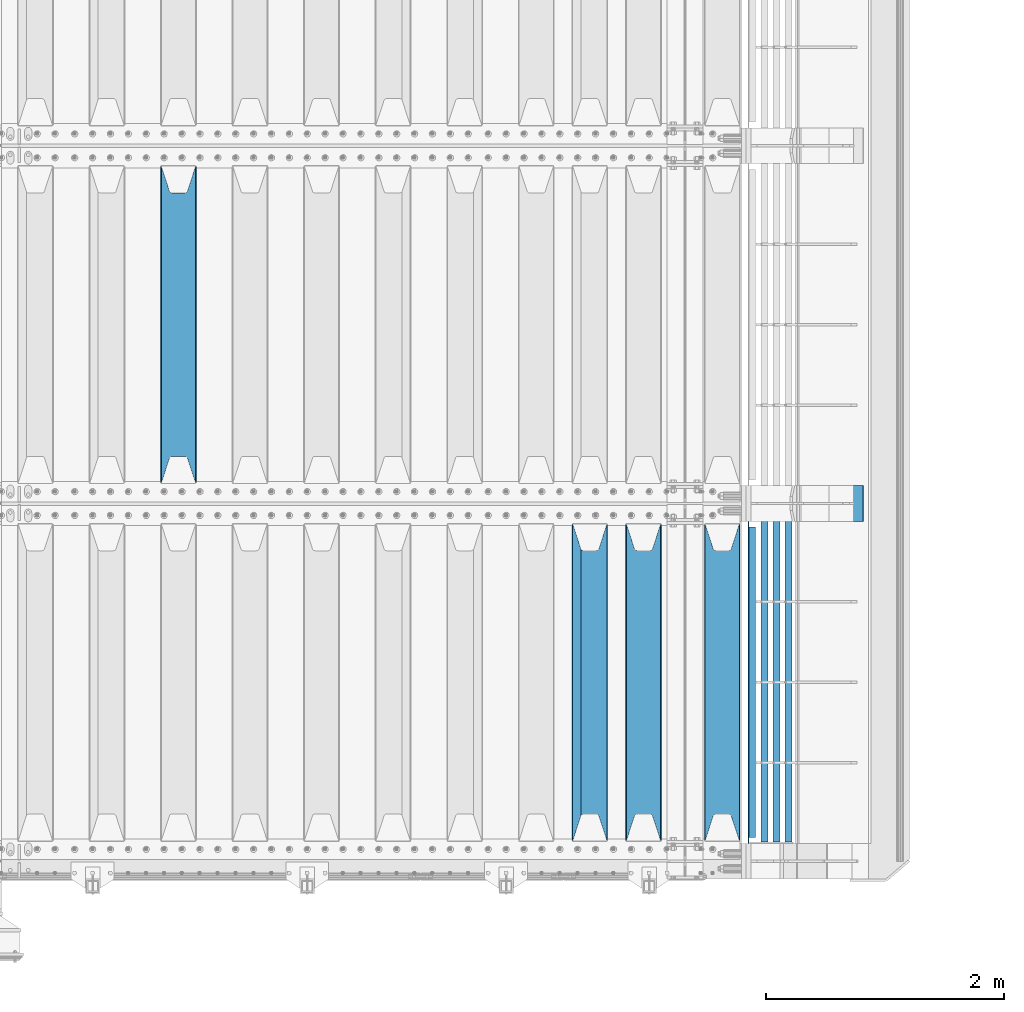
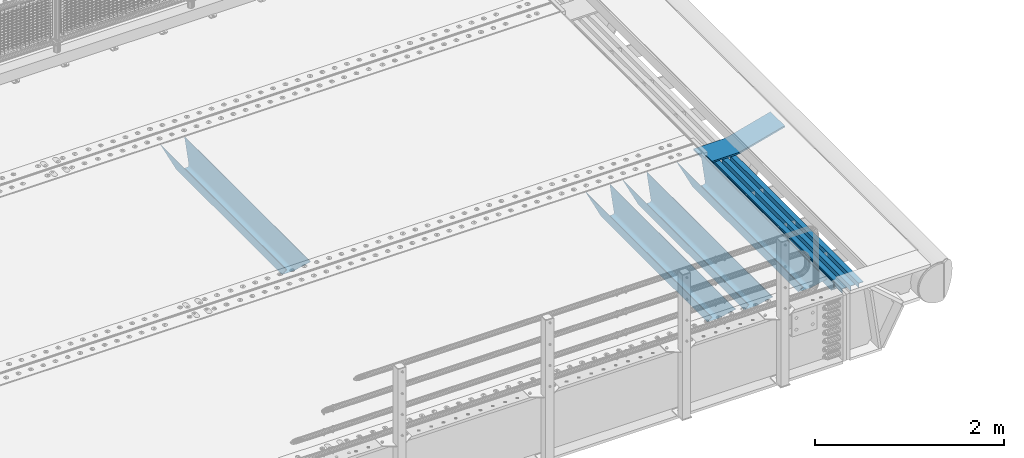
# One storey, part 141 of 270: 9 beams.
"""IFC2X3 building model written with IfcOpenShell, lengths in millimetres."""

from ifc_helpers import new_model, si_unit, frame, origin_with_axes, place, context, subcontext, project, spatial, faceted_brep, material, type_object, element, save


model = new_model("IFC2X3")

# Units and contexts
model_context = context("Model", 3, precision=1e-05, world=origin_with_axes())
body_context = subcontext(model_context, "Body", "Model", "MODEL_VIEW")
ifc_project = project(units=[si_unit("LENGTHUNIT", "METRE", prefix="MILLI"), si_unit("AREAUNIT", "SQUARE_METRE"), si_unit("VOLUMEUNIT", "CUBIC_METRE"), si_unit("MASSUNIT", "GRAM", prefix="KILO"), si_unit("TIMEUNIT", "SECOND"), si_unit("PLANEANGLEUNIT", "RADIAN"), si_unit("SOLIDANGLEUNIT", "STERADIAN"), si_unit("THERMODYNAMICTEMPERATUREUNIT", "DEGREE_CELSIUS"), si_unit("LUMINOUSINTENSITYUNIT", "LUMEN")], contexts=[model_context])

# Site, building, storey
site_placement = place(None, origin_with_axes())
site = spatial("IfcSite", under=ifc_project, at=site_placement, CompositionType="ELEMENT")
building_placement = place(site_placement, origin_with_axes())
building = spatial("IfcBuilding", under=site, at=building_placement, Name="Standard", CompositionType="ELEMENT")
storey_placement = place(building_placement, origin_with_axes())
storey = spatial("IfcBuildingStorey", under=building, at=storey_placement, Name="Undefined", CompositionType="ELEMENT", Elevation=0.0)

# Beams
ifc_material_1 = material(Name="STEEL/S355N")
beam_type_1 = type_object("IfcBeamType", PredefinedType="NOTDEFINED")
beam_1_placement = place(storey_placement, frame((15670.0, -20825.0, -115.0), z_axis=(0.0, 0.0, 1.0), x_axis=(0.0, 1.0, 0.0)))
element("IfcBeam", 1, at=beam_1_placement, inside=storey, type_object=beam_type_1, material=ifc_material_1, context=body_context, shape_type="Brep", body=[
    faceted_brep([(0.0, 150.0, 115.0), (0.0, 143.689999999999, 115.0), (2650.00000000297, 143.689999999999, 115.0), (2650.00000000297, 150.0, 115.0), (2650.00000000297, 142.059565218398, 110.000000003096), (2650.00000000297, 148.3695652184, 110.000000003096), (2441.90079219209, -80.1103600731112, -98.0992078077845), (2437.7588105432, -77.5672621345584, -102.241189456673), (2434.06523489747, -74.4080125315522, -105.934765102404), (2430.9108609509, -70.710272125576, -109.089139048974), (2428.37322971128, -66.5649389910068, -111.626770288588), (2426.51472138055, -62.0739139532889, -113.485278619323), (2425.38102192092, -57.3475956567672, -114.618978078955), (2424.99999999987, -52.5021667386536, -115.0), (2424.99999999987, 52.5021667386536, -115.0), (2425.38102192092, 57.3475956567672, -114.618978078955), (2426.51472138055, 62.0739139532889, -113.485278619323), (2428.37322971128, 66.5649389910068, -111.626770288588), (2430.9108609509, 70.710272125576, -109.089139048974), (2434.06523489747, 74.4080125315522, -105.934765102404), (2437.7588105432, 77.5672621345584, -102.241189456673), (2441.90079219209, 80.1103600731112, -98.0992078077846), (2446.38936140511, 81.9747917625791, -93.6106385947584), (2448.2494850041, 76.2713538057251, -91.7505149957729), (2444.62967112263, 74.76777986261, -95.3703288772456), (2441.28936334126, 72.7168944282894, -98.710636658607), (2438.31067330439, 70.1691124903846, -101.689326695487), (2435.76682334747, 67.1870637758839, -104.233176652398), (2433.72034654133, 63.8440531834895, -106.279653458539), (2432.22154950042, 60.222258798236, -107.778450499454), (2431.30727574265, 56.4107117849089, -108.692724257221), (2430.99999999987, 52.5031078186876, -109.0), (2430.99999999987, -52.5031078186876, -109.0), (2431.30727574265, -56.4107117849089, -108.692724257221), (2432.22154950042, -60.222258798236, -107.778450499454), (2433.72034654133, -63.8440531834895, -106.279653458539), (2435.76682334747, -67.1870637758839, -104.233176652398), (2438.31067330438, -70.1691124903846, -101.689326695487), (2441.28936334126, -72.7168944282894, -98.7106366586071), (2444.62967112263, -74.76777986261, -95.3703288772457), (2448.2494850041, -76.2713538057251, -91.7505149957729), (2650.00000000297, -142.059565218398, 110.000000003096), (2650.00000000297, -148.3695652184, 110.000000003096), (2446.38936140511, -81.9747917625791, -93.6106385947584), (2650.00000000297, -143.689999999999, 115.0), (2650.00000000297, -150.0, 115.0), (0.0, -143.689999999999, 115.0), (0.0, -150.0, 115.0), (0.0, -148.369565218261, 110.000000002672), (203.610638597431, -81.9747917625791, -93.6106385947584), (208.099207810457, -80.1103600731112, -98.0992078077845), (212.241189459342, -77.5672621345584, -102.241189456673), (215.934765105078, -74.4080125315522, -105.934765102404), (219.089139051644, -70.710272125576, -109.089139048974), (221.626770291259, -66.5649389910068, -111.626770288588), (223.485278621993, -62.0739139532889, -113.485278619323), (224.618978081628, -57.3475956567672, -114.618978078955), (225.00000000267, -52.5021667386536, -115.0), (225.00000000267, 52.5021667386536, -115.0), (224.618978081628, 57.3475956567672, -114.618978078955), (223.485278621993, 62.0739139532889, -113.485278619323), (221.626770291259, 66.5649389910068, -111.626770288588), (219.089139051644, 70.710272125576, -109.089139048974), (215.934765105078, 74.4080125315522, -105.934765102404), (212.241189459342, 77.5672621345584, -102.241189456673), (208.099207810457, 80.1103600731112, -98.0992078077846), (203.610638597431, 81.9747917625791, -93.6106385947584), (0.0, 148.369565218261, 110.000000002672), (0.0, 142.05956521826, 110.000000002672), (201.750514998446, 76.2713538057251, -91.7505149957729), (205.370328879915, 74.76777986261, -95.3703288772456), (208.710636661279, 72.7168944282894, -98.710636658607), (211.689326698157, 70.1691124903846, -101.689326695487), (214.233176655071, 67.1870637758839, -104.233176652398), (216.27965346121, 63.8440531834895, -106.279653458539), (217.778450502126, 60.222258798236, -107.778450499454), (218.692724259894, 56.4107117849089, -108.692724257221), (219.00000000267, 52.5031078186876, -109.0), (219.00000000267, -52.5031078186876, -109.0), (218.692724259894, -56.4107117849089, -108.692724257221), (217.778450502123, -60.222258798236, -107.778450499454), (216.27965346121, -63.8440531834895, -106.279653458539), (214.233176655071, -67.1870637758839, -104.233176652398), (211.689326698157, -70.1691124903846, -101.689326695487), (208.710636661279, -72.7168944282894, -98.7106366586071), (205.370328879915, -74.76777986261, -95.3703288772457), (201.750514998446, -76.2713538057251, -91.7505149957729), (0.0, -142.05956521826, 110.000000002672)], [[[0, 1, 2, 3]], [[3, 2, 4, 5]], [[6, 7, 8, 9, 10, 11, 12, 13, 14, 15, 16, 17, 18, 19, 20, 21, 22, 5, 4, 23, 24, 25, 26, 27, 28, 29, 30, 31, 32, 33, 34, 35, 36, 37, 38, 39, 40, 41, 42, 43]], [[44, 45, 42, 41]], [[46, 47, 45, 44]], [[43, 42, 45, 47, 48, 49]], [[6, 43, 49, 50]], [[7, 6, 50, 51]], [[8, 7, 51, 52]], [[9, 8, 52, 53]], [[10, 9, 53, 54]], [[11, 10, 54, 55]], [[12, 11, 55, 56]], [[13, 12, 56, 57]], [[14, 13, 57, 58]], [[15, 14, 58, 59]], [[16, 15, 59, 60]], [[17, 16, 60, 61]], [[18, 17, 61, 62]], [[19, 18, 62, 63]], [[20, 19, 63, 64]], [[21, 20, 64, 65]], [[22, 21, 65, 66]], [[0, 3, 5, 22, 66, 67]], [[1, 0, 67, 68]], [[23, 4, 2, 1, 68, 69]], [[24, 23, 69, 70]], [[25, 24, 70, 71]], [[26, 25, 71, 72]], [[27, 26, 72, 73]], [[28, 27, 73, 74]], [[29, 28, 74, 75]], [[30, 29, 75, 76]], [[31, 30, 76, 77]], [[32, 31, 77, 78]], [[33, 32, 78, 79]], [[34, 33, 79, 80]], [[35, 34, 80, 81]], [[36, 35, 81, 82]], [[37, 36, 82, 83]], [[38, 37, 83, 84]], [[39, 38, 84, 85]], [[40, 39, 85, 86]], [[46, 44, 41, 40, 86, 87]], [[47, 46, 87, 48]], [[86, 85, 84, 83, 82, 81, 80, 79, 78, 77, 76, 75, 74, 73, 72, 71, 70, 69, 68, 67, 66, 65, 64, 63, 62, 61, 60, 59, 58, 57, 56, 55, 54, 53, 52, 51, 50, 49, 48, 87]]]),
])
beam_2_placement = place(storey_placement, frame((20230.0, -23825.0, -115.0), z_axis=(0.0, 0.0, 1.0), x_axis=(0.0, 1.0, 0.0)))
element("IfcBeam", 2, at=beam_2_placement, inside=storey, type_object=beam_type_1, material=ifc_material_1, context=body_context, shape_type="Brep", body=[
    faceted_brep([(0.0, 150.0, 115.0), (0.0, 143.689999999999, 115.0), (2650.00000000297, 143.689999999999, 115.0), (2650.00000000297, 150.0, 115.0), (2650.00000000297, 142.059565218398, 110.000000003096), (2650.00000000297, 148.3695652184, 110.000000003096), (2441.90079219209, -80.1103600731112, -98.0992078077845), (2437.7588105432, -77.5672621345584, -102.241189456673), (2434.06523489747, -74.4080125315522, -105.934765102404), (2430.9108609509, -70.710272125576, -109.089139048974), (2428.37322971128, -66.5649389910068, -111.626770288588), (2426.51472138055, -62.0739139532889, -113.485278619323), (2425.38102192092, -57.3475956567672, -114.618978078955), (2424.99999999987, -52.5021667386536, -115.0), (2424.99999999987, 52.5021667386536, -115.0), (2425.38102192092, 57.3475956567672, -114.618978078955), (2426.51472138055, 62.0739139532889, -113.485278619323), (2428.37322971128, 66.5649389910068, -111.626770288588), (2430.9108609509, 70.710272125576, -109.089139048974), (2434.06523489747, 74.4080125315522, -105.934765102404), (2437.7588105432, 77.5672621345584, -102.241189456673), (2441.90079219209, 80.1103600731112, -98.0992078077846), (2446.38936140511, 81.9747917625791, -93.6106385947584), (2448.2494850041, 76.2713538057251, -91.7505149957729), (2444.62967112263, 74.76777986261, -95.3703288772456), (2441.28936334126, 72.7168944282894, -98.710636658607), (2438.31067330439, 70.1691124903846, -101.689326695487), (2435.76682334747, 67.1870637758839, -104.233176652398), (2433.72034654133, 63.8440531834895, -106.279653458539), (2432.22154950042, 60.222258798236, -107.778450499454), (2431.30727574265, 56.4107117849089, -108.692724257221), (2430.99999999987, 52.5031078186876, -109.0), (2430.99999999987, -52.5031078186876, -109.0), (2431.30727574265, -56.4107117849089, -108.692724257221), (2432.22154950042, -60.222258798236, -107.778450499454), (2433.72034654133, -63.8440531834895, -106.279653458539), (2435.76682334747, -67.1870637758839, -104.233176652398), (2438.31067330438, -70.1691124903846, -101.689326695487), (2441.28936334126, -72.7168944282894, -98.7106366586071), (2444.62967112263, -74.76777986261, -95.3703288772457), (2448.2494850041, -76.2713538057251, -91.7505149957729), (2650.00000000297, -142.059565218398, 110.000000003096), (2650.00000000297, -148.3695652184, 110.000000003096), (2446.38936140511, -81.9747917625791, -93.6106385947584), (2650.00000000297, -143.689999999999, 115.0), (2650.00000000297, -150.0, 115.0), (0.0, -143.689999999999, 115.0), (0.0, -150.0, 115.0), (0.0, -148.369565218261, 110.000000002672), (203.610638597431, -81.9747917625791, -93.6106385947584), (208.099207810457, -80.1103600731112, -98.0992078077845), (212.241189459342, -77.5672621345584, -102.241189456673), (215.934765105078, -74.4080125315522, -105.934765102404), (219.089139051644, -70.710272125576, -109.089139048974), (221.626770291259, -66.5649389910068, -111.626770288588), (223.485278621993, -62.0739139532889, -113.485278619323), (224.618978081628, -57.3475956567672, -114.618978078955), (225.00000000267, -52.5021667386536, -115.0), (225.00000000267, 52.5021667386536, -115.0), (224.618978081628, 57.3475956567672, -114.618978078955), (223.485278621993, 62.0739139532889, -113.485278619323), (221.626770291259, 66.5649389910068, -111.626770288588), (219.089139051644, 70.710272125576, -109.089139048974), (215.934765105078, 74.4080125315522, -105.934765102404), (212.241189459342, 77.5672621345584, -102.241189456673), (208.099207810457, 80.1103600731112, -98.0992078077846), (203.610638597431, 81.9747917625791, -93.6106385947584), (0.0, 148.369565218261, 110.000000002672), (0.0, 142.05956521826, 110.000000002672), (201.750514998446, 76.2713538057251, -91.7505149957729), (205.370328879915, 74.76777986261, -95.3703288772456), (208.710636661279, 72.7168944282894, -98.710636658607), (211.689326698157, 70.1691124903846, -101.689326695487), (214.233176655071, 67.1870637758839, -104.233176652398), (216.27965346121, 63.8440531834895, -106.279653458539), (217.778450502126, 60.222258798236, -107.778450499454), (218.692724259894, 56.4107117849089, -108.692724257221), (219.00000000267, 52.5031078186876, -109.0), (219.00000000267, -52.5031078186876, -109.0), (218.692724259894, -56.4107117849089, -108.692724257221), (217.778450502123, -60.222258798236, -107.778450499454), (216.27965346121, -63.8440531834895, -106.279653458539), (214.233176655071, -67.1870637758839, -104.233176652398), (211.689326698157, -70.1691124903846, -101.689326695487), (208.710636661279, -72.7168944282894, -98.7106366586071), (205.370328879915, -74.76777986261, -95.3703288772457), (201.750514998446, -76.2713538057251, -91.7505149957729), (0.0, -142.05956521826, 110.000000002672)], [[[0, 1, 2, 3]], [[3, 2, 4, 5]], [[6, 7, 8, 9, 10, 11, 12, 13, 14, 15, 16, 17, 18, 19, 20, 21, 22, 5, 4, 23, 24, 25, 26, 27, 28, 29, 30, 31, 32, 33, 34, 35, 36, 37, 38, 39, 40, 41, 42, 43]], [[44, 45, 42, 41]], [[46, 47, 45, 44]], [[43, 42, 45, 47, 48, 49]], [[6, 43, 49, 50]], [[7, 6, 50, 51]], [[8, 7, 51, 52]], [[9, 8, 52, 53]], [[10, 9, 53, 54]], [[11, 10, 54, 55]], [[12, 11, 55, 56]], [[13, 12, 56, 57]], [[14, 13, 57, 58]], [[15, 14, 58, 59]], [[16, 15, 59, 60]], [[17, 16, 60, 61]], [[18, 17, 61, 62]], [[19, 18, 62, 63]], [[20, 19, 63, 64]], [[21, 20, 64, 65]], [[22, 21, 65, 66]], [[0, 3, 5, 22, 66, 67]], [[1, 0, 67, 68]], [[23, 4, 2, 1, 68, 69]], [[24, 23, 69, 70]], [[25, 24, 70, 71]], [[26, 25, 71, 72]], [[27, 26, 72, 73]], [[28, 27, 73, 74]], [[29, 28, 74, 75]], [[30, 29, 75, 76]], [[31, 30, 76, 77]], [[32, 31, 77, 78]], [[33, 32, 78, 79]], [[34, 33, 79, 80]], [[35, 34, 80, 81]], [[36, 35, 81, 82]], [[37, 36, 82, 83]], [[38, 37, 83, 84]], [[39, 38, 84, 85]], [[40, 39, 85, 86]], [[46, 44, 41, 40, 86, 87]], [[47, 46, 87, 48]], [[86, 85, 84, 83, 82, 81, 80, 79, 78, 77, 76, 75, 74, 73, 72, 71, 70, 69, 68, 67, 66, 65, 64, 63, 62, 61, 60, 59, 58, 57, 56, 55, 54, 53, 52, 51, 50, 49, 48, 87]]]),
])
beam_3_placement = place(storey_placement, frame((19570.0, -23825.0, -115.0), z_axis=(0.0, 0.0, 1.0), x_axis=(0.0, 1.0, 0.0)))
element("IfcBeam", 3, at=beam_3_placement, inside=storey, type_object=beam_type_1, material=ifc_material_1, context=body_context, shape_type="Brep", body=[
    faceted_brep([(0.0, 150.0, 115.0), (0.0, 143.689999999999, 115.0), (2650.00000000297, 143.689999999999, 115.0), (2650.00000000297, 150.0, 115.0), (2650.00000000297, 142.059565218398, 110.000000003096), (2650.00000000297, 148.3695652184, 110.000000003096), (2441.90079219209, -80.1103600731112, -98.0992078077845), (2437.7588105432, -77.5672621345584, -102.241189456673), (2434.06523489747, -74.4080125315522, -105.934765102404), (2430.9108609509, -70.710272125576, -109.089139048974), (2428.37322971128, -66.5649389910068, -111.626770288588), (2426.51472138055, -62.0739139532889, -113.485278619323), (2425.38102192092, -57.3475956567672, -114.618978078955), (2424.99999999987, -52.5021667386536, -115.0), (2424.99999999987, 52.5021667386536, -115.0), (2425.38102192092, 57.3475956567672, -114.618978078955), (2426.51472138055, 62.0739139532889, -113.485278619323), (2428.37322971128, 66.5649389910068, -111.626770288588), (2430.9108609509, 70.710272125576, -109.089139048974), (2434.06523489747, 74.4080125315522, -105.934765102404), (2437.7588105432, 77.5672621345584, -102.241189456673), (2441.90079219209, 80.1103600731112, -98.0992078077846), (2446.38936140511, 81.9747917625791, -93.6106385947584), (2448.2494850041, 76.2713538057251, -91.7505149957729), (2444.62967112263, 74.76777986261, -95.3703288772456), (2441.28936334126, 72.7168944282894, -98.710636658607), (2438.31067330439, 70.1691124903846, -101.689326695487), (2435.76682334747, 67.1870637758839, -104.233176652398), (2433.72034654133, 63.8440531834895, -106.279653458539), (2432.22154950042, 60.222258798236, -107.778450499454), (2431.30727574265, 56.4107117849089, -108.692724257221), (2430.99999999987, 52.5031078186876, -109.0), (2430.99999999987, -52.5031078186876, -109.0), (2431.30727574265, -56.4107117849089, -108.692724257221), (2432.22154950042, -60.222258798236, -107.778450499454), (2433.72034654133, -63.8440531834895, -106.279653458539), (2435.76682334747, -67.1870637758839, -104.233176652398), (2438.31067330438, -70.1691124903846, -101.689326695487), (2441.28936334126, -72.7168944282894, -98.7106366586071), (2444.62967112263, -74.76777986261, -95.3703288772457), (2448.2494850041, -76.2713538057251, -91.7505149957729), (2650.00000000297, -142.059565218398, 110.000000003096), (2650.00000000297, -148.3695652184, 110.000000003096), (2446.38936140511, -81.9747917625791, -93.6106385947584), (2650.00000000297, -143.689999999999, 115.0), (2650.00000000297, -150.0, 115.0), (0.0, -143.689999999999, 115.0), (0.0, -150.0, 115.0), (0.0, -148.369565218261, 110.000000002672), (203.610638597431, -81.9747917625791, -93.6106385947584), (208.099207810457, -80.1103600731112, -98.0992078077845), (212.241189459342, -77.5672621345584, -102.241189456673), (215.934765105078, -74.4080125315522, -105.934765102404), (219.089139051644, -70.710272125576, -109.089139048974), (221.626770291259, -66.5649389910068, -111.626770288588), (223.485278621993, -62.0739139532889, -113.485278619323), (224.618978081628, -57.3475956567672, -114.618978078955), (225.00000000267, -52.5021667386536, -115.0), (225.00000000267, 52.5021667386536, -115.0), (224.618978081628, 57.3475956567672, -114.618978078955), (223.485278621993, 62.0739139532889, -113.485278619323), (221.626770291259, 66.5649389910068, -111.626770288588), (219.089139051644, 70.710272125576, -109.089139048974), (215.934765105078, 74.4080125315522, -105.934765102404), (212.241189459342, 77.5672621345584, -102.241189456673), (208.099207810457, 80.1103600731112, -98.0992078077846), (203.610638597431, 81.9747917625791, -93.6106385947584), (0.0, 148.369565218261, 110.000000002672), (0.0, 142.05956521826, 110.000000002672), (201.750514998446, 76.2713538057251, -91.7505149957729), (205.370328879915, 74.76777986261, -95.3703288772456), (208.710636661279, 72.7168944282894, -98.710636658607), (211.689326698157, 70.1691124903846, -101.689326695487), (214.233176655071, 67.1870637758839, -104.233176652398), (216.27965346121, 63.8440531834895, -106.279653458539), (217.778450502126, 60.222258798236, -107.778450499454), (218.692724259894, 56.4107117849089, -108.692724257221), (219.00000000267, 52.5031078186876, -109.0), (219.00000000267, -52.5031078186876, -109.0), (218.692724259894, -56.4107117849089, -108.692724257221), (217.778450502123, -60.222258798236, -107.778450499454), (216.27965346121, -63.8440531834895, -106.279653458539), (214.233176655071, -67.1870637758839, -104.233176652398), (211.689326698157, -70.1691124903846, -101.689326695487), (208.710636661279, -72.7168944282894, -98.7106366586071), (205.370328879915, -74.76777986261, -95.3703288772457), (201.750514998446, -76.2713538057251, -91.7505149957729), (0.0, -142.05956521826, 110.000000002672)], [[[0, 1, 2, 3]], [[3, 2, 4, 5]], [[6, 7, 8, 9, 10, 11, 12, 13, 14, 15, 16, 17, 18, 19, 20, 21, 22, 5, 4, 23, 24, 25, 26, 27, 28, 29, 30, 31, 32, 33, 34, 35, 36, 37, 38, 39, 40, 41, 42, 43]], [[44, 45, 42, 41]], [[46, 47, 45, 44]], [[43, 42, 45, 47, 48, 49]], [[6, 43, 49, 50]], [[7, 6, 50, 51]], [[8, 7, 51, 52]], [[9, 8, 52, 53]], [[10, 9, 53, 54]], [[11, 10, 54, 55]], [[12, 11, 55, 56]], [[13, 12, 56, 57]], [[14, 13, 57, 58]], [[15, 14, 58, 59]], [[16, 15, 59, 60]], [[17, 16, 60, 61]], [[18, 17, 61, 62]], [[19, 18, 62, 63]], [[20, 19, 63, 64]], [[21, 20, 64, 65]], [[22, 21, 65, 66]], [[0, 3, 5, 22, 66, 67]], [[1, 0, 67, 68]], [[23, 4, 2, 1, 68, 69]], [[24, 23, 69, 70]], [[25, 24, 70, 71]], [[26, 25, 71, 72]], [[27, 26, 72, 73]], [[28, 27, 73, 74]], [[29, 28, 74, 75]], [[30, 29, 75, 76]], [[31, 30, 76, 77]], [[32, 31, 77, 78]], [[33, 32, 78, 79]], [[34, 33, 79, 80]], [[35, 34, 80, 81]], [[36, 35, 81, 82]], [[37, 36, 82, 83]], [[38, 37, 83, 84]], [[39, 38, 84, 85]], [[40, 39, 85, 86]], [[46, 44, 41, 40, 86, 87]], [[47, 46, 87, 48]], [[86, 85, 84, 83, 82, 81, 80, 79, 78, 77, 76, 75, 74, 73, 72, 71, 70, 69, 68, 67, 66, 65, 64, 63, 62, 61, 60, 59, 58, 57, 56, 55, 54, 53, 52, 51, 50, 49, 48, 87]]]),
])
beam_4_placement = place(storey_placement, frame((19120.0, -23825.0, -115.0), z_axis=(0.0, 0.0, 1.0), x_axis=(0.0, 1.0, 0.0)))
element("IfcBeam", 4, at=beam_4_placement, inside=storey, type_object=beam_type_1, material=ifc_material_1, context=body_context, shape_type="Brep", body=[
    faceted_brep([(0.0, 150.0, 115.0), (0.0, 143.689999999999, 115.0), (2650.00000000297, 143.689999999999, 115.0), (2650.00000000297, 150.0, 115.0), (2650.00000000297, 142.059565218398, 110.000000003096), (2650.00000000297, 148.3695652184, 110.000000003096), (2441.90079219209, -80.1103600731112, -98.0992078077845), (2437.7588105432, -77.5672621345584, -102.241189456673), (2434.06523489747, -74.4080125315522, -105.934765102404), (2430.9108609509, -70.710272125576, -109.089139048974), (2428.37322971128, -66.5649389910068, -111.626770288588), (2426.51472138055, -62.0739139532889, -113.485278619323), (2425.38102192092, -57.3475956567672, -114.618978078955), (2424.99999999987, -52.5021667386536, -115.0), (2424.99999999987, 52.5021667386536, -115.0), (2425.38102192092, 57.3475956567672, -114.618978078955), (2426.51472138055, 62.0739139532889, -113.485278619323), (2428.37322971128, 66.5649389910068, -111.626770288588), (2430.9108609509, 70.710272125576, -109.089139048974), (2434.06523489747, 74.4080125315522, -105.934765102404), (2437.7588105432, 77.5672621345584, -102.241189456673), (2441.90079219209, 80.1103600731112, -98.0992078077846), (2446.38936140511, 81.9747917625791, -93.6106385947584), (2448.2494850041, 76.2713538057251, -91.7505149957729), (2444.62967112263, 74.76777986261, -95.3703288772456), (2441.28936334126, 72.7168944282894, -98.710636658607), (2438.31067330439, 70.1691124903846, -101.689326695487), (2435.76682334747, 67.1870637758839, -104.233176652398), (2433.72034654133, 63.8440531834895, -106.279653458539), (2432.22154950042, 60.222258798236, -107.778450499454), (2431.30727574265, 56.4107117849089, -108.692724257221), (2430.99999999987, 52.5031078186876, -109.0), (2430.99999999987, -52.5031078186876, -109.0), (2431.30727574265, -56.4107117849089, -108.692724257221), (2432.22154950042, -60.222258798236, -107.778450499454), (2433.72034654133, -63.8440531834895, -106.279653458539), (2435.76682334747, -67.1870637758839, -104.233176652398), (2438.31067330438, -70.1691124903846, -101.689326695487), (2441.28936334126, -72.7168944282894, -98.7106366586071), (2444.62967112263, -74.76777986261, -95.3703288772457), (2448.2494850041, -76.2713538057251, -91.7505149957729), (2650.00000000297, -142.059565218398, 110.000000003096), (2650.00000000297, -148.3695652184, 110.000000003096), (2446.38936140511, -81.9747917625791, -93.6106385947584), (2650.00000000297, -143.689999999999, 115.0), (2650.00000000297, -150.0, 115.0), (0.0, -143.689999999999, 115.0), (0.0, -150.0, 115.0), (0.0, -148.369565218261, 110.000000002672), (203.610638597431, -81.9747917625791, -93.6106385947584), (208.099207810457, -80.1103600731112, -98.0992078077845), (212.241189459342, -77.5672621345584, -102.241189456673), (215.934765105078, -74.4080125315522, -105.934765102404), (219.089139051644, -70.710272125576, -109.089139048974), (221.626770291259, -66.5649389910068, -111.626770288588), (223.485278621993, -62.0739139532889, -113.485278619323), (224.618978081628, -57.3475956567672, -114.618978078955), (225.00000000267, -52.5021667386536, -115.0), (225.00000000267, 52.5021667386536, -115.0), (224.618978081628, 57.3475956567672, -114.618978078955), (223.485278621993, 62.0739139532889, -113.485278619323), (221.626770291259, 66.5649389910068, -111.626770288588), (219.089139051644, 70.710272125576, -109.089139048974), (215.934765105078, 74.4080125315522, -105.934765102404), (212.241189459342, 77.5672621345584, -102.241189456673), (208.099207810457, 80.1103600731112, -98.0992078077846), (203.610638597431, 81.9747917625791, -93.6106385947584), (0.0, 148.369565218261, 110.000000002672), (0.0, 142.05956521826, 110.000000002672), (201.750514998446, 76.2713538057251, -91.7505149957729), (205.370328879915, 74.76777986261, -95.3703288772456), (208.710636661279, 72.7168944282894, -98.710636658607), (211.689326698157, 70.1691124903846, -101.689326695487), (214.233176655071, 67.1870637758839, -104.233176652398), (216.27965346121, 63.8440531834895, -106.279653458539), (217.778450502126, 60.222258798236, -107.778450499454), (218.692724259894, 56.4107117849089, -108.692724257221), (219.00000000267, 52.5031078186876, -109.0), (219.00000000267, -52.5031078186876, -109.0), (218.692724259894, -56.4107117849089, -108.692724257221), (217.778450502123, -60.222258798236, -107.778450499454), (216.27965346121, -63.8440531834895, -106.279653458539), (214.233176655071, -67.1870637758839, -104.233176652398), (211.689326698157, -70.1691124903846, -101.689326695487), (208.710636661279, -72.7168944282894, -98.7106366586071), (205.370328879915, -74.76777986261, -95.3703288772457), (201.750514998446, -76.2713538057251, -91.7505149957729), (0.0, -142.05956521826, 110.000000002672)], [[[0, 1, 2, 3]], [[3, 2, 4, 5]], [[6, 7, 8, 9, 10, 11, 12, 13, 14, 15, 16, 17, 18, 19, 20, 21, 22, 5, 4, 23, 24, 25, 26, 27, 28, 29, 30, 31, 32, 33, 34, 35, 36, 37, 38, 39, 40, 41, 42, 43]], [[44, 45, 42, 41]], [[46, 47, 45, 44]], [[43, 42, 45, 47, 48, 49]], [[6, 43, 49, 50]], [[7, 6, 50, 51]], [[8, 7, 51, 52]], [[9, 8, 52, 53]], [[10, 9, 53, 54]], [[11, 10, 54, 55]], [[12, 11, 55, 56]], [[13, 12, 56, 57]], [[14, 13, 57, 58]], [[15, 14, 58, 59]], [[16, 15, 59, 60]], [[17, 16, 60, 61]], [[18, 17, 61, 62]], [[19, 18, 62, 63]], [[20, 19, 63, 64]], [[21, 20, 64, 65]], [[22, 21, 65, 66]], [[0, 3, 5, 22, 66, 67]], [[1, 0, 67, 68]], [[23, 4, 2, 1, 68, 69]], [[24, 23, 69, 70]], [[25, 24, 70, 71]], [[26, 25, 71, 72]], [[27, 26, 72, 73]], [[28, 27, 73, 74]], [[29, 28, 74, 75]], [[30, 29, 75, 76]], [[31, 30, 76, 77]], [[32, 31, 77, 78]], [[33, 32, 78, 79]], [[34, 33, 79, 80]], [[35, 34, 80, 81]], [[36, 35, 81, 82]], [[37, 36, 82, 83]], [[38, 37, 83, 84]], [[39, 38, 84, 85]], [[40, 39, 85, 86]], [[46, 44, 41, 40, 86, 87]], [[47, 46, 87, 48]], [[86, 85, 84, 83, 82, 81, 80, 79, 78, 77, 76, 75, 74, 73, 72, 71, 70, 69, 68, 67, 66, 65, 64, 63, 62, 61, 60, 59, 58, 57, 56, 55, 54, 53, 52, 51, 50, 49, 48, 87]]]),
])
ifc_material_2 = material(Name="STEEL/S355J2")
beam_type_2 = type_object("IfcBeamType", PredefinedType="NOTDEFINED")
beam_5_placement = place(storey_placement, frame((20477.5025260065, -23850.0, -124.999999999977), z_axis=(0.0, 0.0, 1.0), x_axis=(0.0, 1.0, 0.0)))
element("IfcBeam", 5, at=beam_5_placement, inside=storey, type_object=beam_type_2, material=ifc_material_2, context=body_context, shape_type="Brep", body=[
    faceted_brep([(2700.0, 22.5, -15.0), (2684.54915028125, 22.5, -17.4471741852423), (2684.54915028125, 32.5, -17.4471741852423), (2700.0, 32.5, -15.0), (2670.61073738538, 22.5, -24.5491502812526), (2670.61073738538, 32.5, -24.5491502812526), (2659.54915028125, 22.5, -35.6107373853764), (2659.54915028125, 32.5, -35.6107373853764), (2652.44717418524, 22.5, -49.5491502812526), (2652.44717418524, 32.5, -49.5491502812526), (2651.58384440325, -32.5, -55.0), (2650.0, -32.5, -65.0), (2650.0, 32.5, -65.0), (2651.58384440325, 22.5, -55.0), (0.0, 32.5, 65.0), (0.0, 22.5, 65.0), (2700.0, 22.5, 65.0), (2700.0, 32.5, 65.0), (0.0, 32.5, -15.0), (0.0, 22.5, -15.0), (15.4508497187489, 32.5, -17.4471741852423), (15.4508497187489, 22.5, -17.4471741852423), (29.3892626146226, 32.5, -24.5491502812526), (29.3892626146226, 22.5, -24.5491502812526), (40.4508497187489, 32.5, -35.6107373853763), (40.4508497187489, 22.5, -35.6107373853763), (47.5528258147569, 32.5, -49.5491502812526), (47.5528258147569, 22.5, -49.5491502812526), (50.0, -32.5, -65.0), (48.4161555967512, -32.5, -55.0), (48.4161555967512, 22.5, -55.0), (50.0, 32.5, -65.0)], [[[0, 1, 2, 3]], [[4, 5, 2, 1]], [[6, 7, 5, 4]], [[8, 9, 7, 6]], [[10, 11, 12, 9, 8, 13]], [[14, 15, 16, 17]], [[15, 14, 18, 19]], [[19, 18, 20, 21]], [[21, 20, 22, 23]], [[23, 22, 24, 25]], [[25, 24, 26, 27]], [[28, 29, 30, 27, 26, 31]], [[30, 29, 10, 13]], [[16, 15, 19, 21, 23, 25, 27, 30, 13, 8, 6, 4, 1, 0]], [[17, 16, 0, 3]], [[5, 7, 9, 12, 31, 26, 24, 22, 20, 18, 14, 17, 3, 2]], [[28, 31, 12, 11]], [[29, 28, 11, 10]]]),
])
beam_type_3 = type_object("IfcBeamType", PredefinedType="NOTDEFINED")
beam_6_placement = place(storey_placement, frame((20469.9988298906, -21000.0, -169.999999999995), z_axis=(0.0, -1.0, 0.0), x_axis=(1.0, 0.0, 0.0)))
element("IfcBeam", 6, at=beam_6_placement, inside=storey, type_object=beam_type_3, material=ifc_material_1, context=body_context, shape_type="Brep", body=[
    faceted_brep([(0.0, 10.0, -150.0), (0.0, 10.0, 150.0), (356.495387467741, 10.0, 150.0), (356.495387467749, 9.99999999999901, -150.0), (0.0, -10.0, 150.0), (0.0, -10.0, -150.0), (356.495387467741, -10.0, -150.0), (356.495387467741, -10.0, 150.0), (382.770279632416, 11.7334369044542, 150.0), (382.770279632416, 11.7334369044542, -150.0), (385.397768848896, -8.09321940509935, -150.0), (385.397768848896, -8.09321940509935, 150.0), (413.799145684919, -2.40593045895554, -150.0), (413.799145684919, -2.40593045895554, 150.0), (408.589713119687, 16.9036995827646, 150.0), (408.589713119891, 16.9036995827009, -150.0), (939.000000000015, 160.0, 150.0), (939.000000000015, 160.0, -150.0), (944.209432565229, 140.69036995827, 150.0), (944.209432565229, 140.69036995827, -150.0)], [[[0, 1, 2, 3]], [[4, 5, 6, 7]], [[5, 4, 1, 0]], [[3, 2, 8, 9]], [[7, 6, 10, 11]], [[10, 12, 13, 11]], [[8, 14, 15, 9]], [[15, 14, 16, 17]], [[14, 8, 2, 1, 4, 7, 11, 13, 18, 16]], [[13, 12, 19, 18]], [[12, 10, 6, 5, 0, 3, 9, 15, 17, 19]], [[18, 19, 17, 16]]]),
])
beam_type_4 = type_object("IfcBeamType", PredefinedType="NOTDEFINED")
for number, where, z_axis, x_axis in (
    (7, (20785.0024147167, -21130.0000023409, -210.000211453654), (0.0, 0.0, -1.0), (0.0, -1.0, 0.0)),
    (8, (20685.0024147167, -21130.0000023409, -210.000211453654), (0.0, 0.0, -1.0), (0.0, -1.0, 0.0)),
    (9, (20585.002414716, -21130.0000023409, -210.000211453713), (0.0, 0.0, -1.0), (0.0, -1.0, 0.0)),
):
    element("IfcBeam", number, at=place(storey_placement, frame(where, z_axis=z_axis, x_axis=x_axis)), inside=storey, type_object=beam_type_4, material=ifc_material_2, context=body_context, shape_type="Brep", body=[
        faceted_brep([(3.63797880709171e-12, 29.9999999999927, -30.0), (0.0, 29.9999999999927, 30.0000000000001), (2710.00000000001, 29.9999999999927, 30.0000000000001), (2710.00000000001, 29.9999999999927, -30.0), (0.0, 23.9999999999927, 30.0), (2710.00000000001, 23.9999999999927, 30.0), (0.0, 23.9999999999927, -24.0), (2710.00000000001, 23.9999999999927, -24.0), (0.0, -30.0000000000073, -24.0), (2710.00000000001, -30.0000000000073, -24.0), (0.0, -30.0000000000073, -30.0), (2710.00000000001, -30.0000000000073, -30.0)], [[[0, 1, 2, 3]], [[1, 4, 5, 2]], [[4, 6, 7, 5]], [[6, 8, 9, 7]], [[8, 10, 11, 9]], [[10, 0, 3, 11]], [[5, 7, 9, 11, 3, 2]], [[10, 8, 6, 4, 1, 0]]]),
    ])

save(model, "model.ifc")
